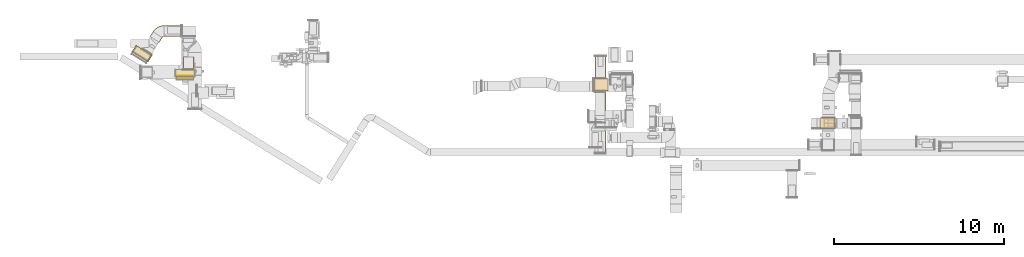
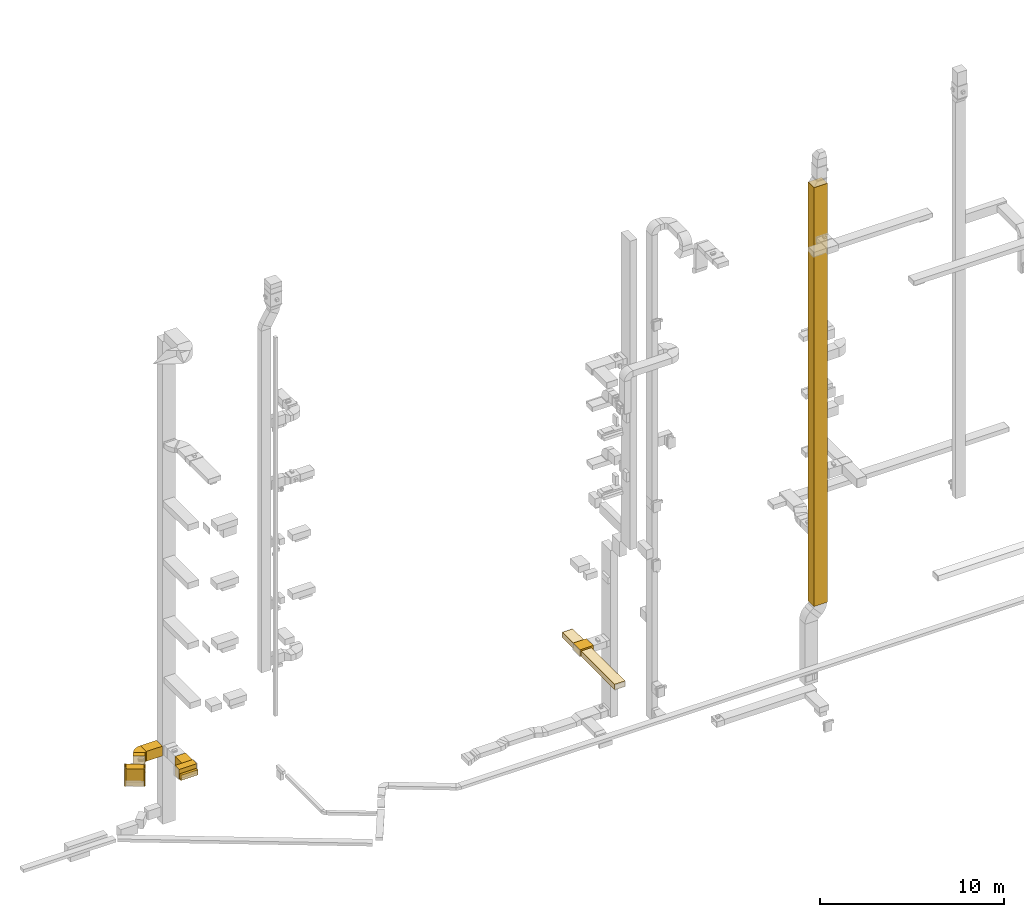
# One storey, part 1 of 29: 14 coverings.
"""IFC2X3 building model written with IfcOpenShell, lengths in millimetres."""

from ifc_helpers import new_model, entity, si_unit, converted_unit, derived_unit, direction, frame, frame_2d, origin, origin_2d_with_axis, place, context, subcontext, project, spatial, polyline, circle_curve, parameter, trimmed, segment, composite_curve, rectangle, outline, extrude, element, save


model = new_model("IFC2X3")

# Units and contexts
model_context = context("Model", 3, precision=0.01, world=origin(), true_north=direction((6.12303176911189e-17, 1.0)))
body_context = subcontext(model_context, "Body", "Model", "MODEL_VIEW")
ifc_project = project(units=[si_unit("LENGTHUNIT", "METRE", prefix="MILLI"), si_unit("AREAUNIT", "SQUARE_METRE"), si_unit("VOLUMEUNIT", "CUBIC_METRE"), converted_unit("PLANEANGLEUNIT", "DEGREE", entity("IfcRatioMeasure", 0.0174532925199433), si_unit("PLANEANGLEUNIT", "RADIAN"), dimensions=[0, 0, 0, 0, 0, 0, 0]), si_unit("MASSUNIT", "GRAM", prefix="KILO"), derived_unit("MASSDENSITYUNIT", [(si_unit("MASSUNIT", "GRAM", prefix="KILO"), 1), (si_unit("LENGTHUNIT", "METRE"), -3)]), derived_unit("MOMENTOFINERTIAUNIT", [(si_unit("LENGTHUNIT", "METRE"), 4)]), si_unit("TIMEUNIT", "SECOND"), si_unit("FREQUENCYUNIT", "HERTZ"), si_unit("THERMODYNAMICTEMPERATUREUNIT", "DEGREE_CELSIUS"), derived_unit("THERMALTRANSMITTANCEUNIT", [(si_unit("MASSUNIT", "GRAM", prefix="KILO"), 1), (si_unit("THERMODYNAMICTEMPERATUREUNIT", "KELVIN"), -1), (si_unit("TIMEUNIT", "SECOND"), -3)]), derived_unit("VOLUMETRICFLOWRATEUNIT", [(si_unit("LENGTHUNIT", "METRE"), 3), (si_unit("TIMEUNIT", "SECOND"), -1)]), derived_unit("MASSFLOWRATEUNIT", [(si_unit("MASSUNIT", "GRAM", prefix="KILO"), 1), (si_unit("TIMEUNIT", "SECOND"), -1)]), derived_unit("ROTATIONALFREQUENCYUNIT", [(si_unit("TIMEUNIT", "SECOND"), -1)]), si_unit("ELECTRICCURRENTUNIT", "AMPERE"), si_unit("ELECTRICVOLTAGEUNIT", "VOLT"), si_unit("POWERUNIT", "WATT"), si_unit("FORCEUNIT", "NEWTON", prefix="KILO"), si_unit("ILLUMINANCEUNIT", "LUX"), si_unit("LUMINOUSFLUXUNIT", "LUMEN"), si_unit("LUMINOUSINTENSITYUNIT", "CANDELA"), derived_unit("USERDEFINED", [(si_unit("MASSUNIT", "GRAM", prefix="KILO"), -1), (si_unit("LENGTHUNIT", "METRE"), -2), (si_unit("TIMEUNIT", "SECOND"), 3), (si_unit("LUMINOUSFLUXUNIT", "LUMEN"), 1)]), derived_unit("LINEARVELOCITYUNIT", [(si_unit("LENGTHUNIT", "METRE"), 1), (si_unit("TIMEUNIT", "SECOND"), -1)]), si_unit("PRESSUREUNIT", "PASCAL"), derived_unit("USERDEFINED", [(si_unit("LENGTHUNIT", "METRE"), -2), (si_unit("MASSUNIT", "GRAM", prefix="KILO"), 1), (si_unit("TIMEUNIT", "SECOND"), -2)]), derived_unit("LINEARFORCEUNIT", [(si_unit("MASSUNIT", "GRAM", prefix="KILO"), 1), (si_unit("LENGTHUNIT", "METRE"), 1), (si_unit("TIMEUNIT", "SECOND"), -2), (si_unit("LENGTHUNIT", "METRE"), -1)]), derived_unit("PLANARFORCEUNIT", [(si_unit("MASSUNIT", "GRAM", prefix="KILO"), 1), (si_unit("LENGTHUNIT", "METRE"), 1), (si_unit("TIMEUNIT", "SECOND"), -2), (si_unit("LENGTHUNIT", "METRE"), -2)])], contexts=[model_context])

# Site, building, storey
site_placement = place(None, frame((0.0, -0.00077364408347762, 0.0)))
site = spatial("IfcSite", under=ifc_project, at=site_placement, CompositionType="ELEMENT")
building_placement = place(site_placement, origin())
building = spatial("IfcBuilding", under=site, at=building_placement, CompositionType="ELEMENT")
storey_placement = place(building_placement, origin())
storey = spatial("IfcBuildingStorey", under=building, at=storey_placement, CompositionType="ELEMENT", Elevation=0.0)

# Coverings
covering_1_placement = place(storey_placement, frame((28415.0012184742, 12772.7217701701, 2475.0)))
element("IfcCovering", 1, at=covering_1_placement, inside=storey, PredefinedType="INSULATION", context=body_context, shape_type="SweptSolid", body=[
    extrude(rectangle(XDim=825.107316474216, YDim=749.999999999998, at=frame_2d((0.0, -1.08002495835535e-12), x_axis=(1.0, 0.0))), frame((412.553658237108, 375.0, 0.0), z_axis=(0.0, 0.0, 1.0), x_axis=(-1.0, 0.0, 0.0)), (0.0, 0.0, 1.0), 449.999999999999),
])
covering_2_placement = place(storey_placement, frame((28476.0506788633, 13517.7217701701, 2475.0)))
element("IfcCovering", 2, at=covering_2_placement, inside=storey, PredefinedType="INSULATION", context=body_context, shape_type="SweptSolid", body=[
    extrude(rectangle(XDim=1299.51814618853, YDim=650.0, at=frame_2d((-1.08002495835535e-12, 2.1600499167107e-12), x_axis=(1.0, 0.0))), frame((325.0, 649.759073094305, 0.0), z_axis=(0.0, 0.0, 1.0), x_axis=(0.0, 1.0, 0.0)), (0.0, 0.0, 1.0), 350.000000000001),
])
covering_3_placement = place(storey_placement, frame((28464.0983074609, 9142.07579712691, 2475.0)))
element("IfcCovering", 3, at=covering_3_placement, inside=storey, PredefinedType="INSULATION", context=body_context, shape_type="SweptSolid", body=[
    extrude(rectangle(XDim=3635.64597304317, YDim=650.0, at=frame_2d((-5.6843418860808e-13, 0.0), x_axis=(1.0, 0.0))), frame((325.0, 1817.82298652159, 0.0), z_axis=(0.0, 0.0, 1.0), x_axis=(0.0, -1.0, 0.0)), (0.0, 0.0, 1.0), 350.000000000001),
])
covering_4_placement = place(storey_placement, frame((4213.73846384671, 14052.5, 2475.0)))
element("IfcCovering", 4, at=covering_4_placement, inside=storey, PredefinedType="INSULATION", context=body_context, shape_type="SweptSolid", body=[
    extrude(rectangle(XDim=738.844290776113, YDim=650.0, at=origin_2d_with_axis()), frame((325.0, 369.422145388058, 0.0), z_axis=(0.0, 0.0, 1.0), x_axis=(0.0, -1.0, 0.0)), (0.0, 0.0, 1.0), 650.000000000001),
])
covering_5_placement = place(storey_placement, frame((3813.73846384665, 13450.1017206743, 2475.0)))
element("IfcCovering", 5, at=covering_5_placement, inside=storey, PredefinedType="INSULATION", context=body_context, shape_type="SweptSolid", body=[
    extrude(rectangle(XDim=162.39827932573, YDim=1050.0, at=frame_2d((0.0, 2.8421709430404e-13), x_axis=(1.0, 0.0))), frame((525.0, 81.1991396628746, 0.0), z_axis=(0.0, 0.0, 1.0), x_axis=(0.0, 1.0, 0.0)), (0.0, 0.0, 1.0), 349.999999999999),
])
covering_6_placement = place(storey_placement, frame((3785.84688819858, 13607.5, 2475.0)))
element("IfcCovering", 6, at=covering_6_placement, inside=storey, PredefinedType="INSULATION", context=body_context, shape_type="SweptSolid", body=[
    extrude(rectangle(XDim=1100.0, YDim=450.000000000002, at=origin_2d_with_axis()), frame((550.0, 225.0, 0.0)), (0.0, 0.0, 1.0), 650.000000000001),
])
covering_7_placement = place(storey_placement, frame((3813.73846384665, 13612.5, 2475.0)))
element("IfcCovering", 7, at=covering_7_placement, inside=storey, PredefinedType="INSULATION", context=body_context, shape_type="SweptSolid", body=[
    extrude(rectangle(XDim=1050.0, YDim=51.0959999999994, at=frame_2d((-2.8421709430404e-13, 2.16537898722891e-12), x_axis=(1.0, 0.0))), frame((525.0, 25.5479999999986, 0.0)), (0.0, 0.0, 1.0), 349.999999999999),
])
covering_8_placement = place(storey_placement, frame((1272.46372759647, 14529.8528003857, 2025.0)))
element("IfcCovering", 8, at=covering_8_placement, inside=storey, PredefinedType="INSULATION", context=body_context, shape_type="SweptSolid", body=[
    extrude(rectangle(XDim=1000.0, YDim=449.999999999999, at=frame_2d((-5.96855898038484e-13, 9.37916411203332e-13), x_axis=(1.0, 0.0))), frame((543.255882522377, 455.770453785952, 0.0), z_axis=(0.0, 0.0, 1.0), x_axis=(0.848048096097044, -0.529919264328235, 0.0)), (0.0, 0.0, 1.0), 1150.0),
])
covering_9_placement = place(storey_placement, frame((1230.06132279162, 15059.772064714, 2025.0)))
element("IfcCovering", 9, at=covering_9_placement, inside=storey, PredefinedType="INSULATION", context=body_context, shape_type="SweptSolid", body=[
    extrude(rectangle(XDim=50.0000000000009, YDim=450.0, at=frame_2d((-4.65405491922866e-13, 9.80548975348938e-13), x_axis=(1.0, 0.0))), frame((140.43303687628, 204.058803230039, 0.0), z_axis=(0.0, 0.0, 1.0), x_axis=(0.848048096097048, -0.52991926432823, 0.0)), (0.0, 0.0, 1.0), 1150.0),
])
covering_10_placement = place(storey_placement, frame((3108.61579884427, 15984.9756321925, 2460.0)))
element("IfcCovering", 10, at=covering_10_placement, inside=storey, PredefinedType="INSULATION", context=body_context, shape_type="SweptSolid", body=[
    extrude(rectangle(XDim=1014.71471811025, YDim=650.0, at=origin_2d_with_axis()), frame((507.357359055125, 325.0, 0.0), z_axis=(0.0, 0.0, 1.0), x_axis=(-1.0, 0.0, 0.0)), (0.0, 0.0, 1.0), 650.000000000001),
])
covering_11_placement = place(storey_placement, frame((2276.07139059339, 15645.665480935, 2460.0)))
element("IfcCovering", 11, at=covering_11_placement, inside=storey, PredefinedType="INSULATION", context=body_context, shape_type="SweptSolid", body=[
    extrude(rectangle(XDim=330.818571009889, YDim=649.999999999998, at=frame_2d((7.8159700933611e-13, 8.24229573481716e-13), x_axis=(1.0, 0.0))), frame((363.269198119378, 312.498790555917, 0.0), z_axis=(0.0, 0.0, 1.0), x_axis=(-0.529919264328237, -0.848048096097043, 0.0)), (0.0, 0.0, 1.0), 649.999999999999),
])
covering_12_placement = place(storey_placement, frame((2120.51182369352, 14503.3568371693, 2025.0)))
element("IfcCovering", 12, at=covering_12_placement, inside=storey, PredefinedType="INSULATION", context=body_context, shape_type="SweptSolid", body=[
    extrude(rectangle(XDim=50.0000000000007, YDim=450.0, at=frame_2d((4.65405491922866e-13, -9.9475983006414e-13), x_axis=(1.0, 0.0))), frame((140.43303687628, 204.058803230037, 0.0), z_axis=(0.0, 0.0, 1.0), x_axis=(-0.848048096097046, 0.529919264328233, 0.0)), (0.0, 0.0, 1.0), 1150.0),
])
covering_13_placement = place(storey_placement, frame((2449.78325213316, 15924.6202679976, 2460.0)))
element("IfcCovering", 13, at=covering_13_placement, inside=storey, PredefinedType="INSULATION", context=body_context, shape_type="SweptSolid", body=[
    extrude(outline(composite_curve([segment(polyline([(-277.991926432823, 84.8048096097035), (66.4555953805334, -466.426452853373)]), True, "CONTINUOUS"), segment(trimmed(circle_curve(frame_2d((-344.231834473854, 190.810821621833), x_axis=(1.0, 0.0)), 775.0), [parameter(302.000000006421)], [parameter(0.0)], True, "PARAMETER"), True, "CONTINUOUS"), segment(polyline([(430.768165526145, 190.810821621833), (-219.231834473854, 190.810821621833)]), True, "CONTINUOUS"), segment(trimmed(circle_curve(frame_2d((-344.231834473854, 190.810821621833), x_axis=(1.0, 0.0)), 125.0), [parameter(302.00000000642)], [parameter(360.0)], True, "PARAMETER"), False, "CONTINUOUS")], self_intersect=False)), frame((468.021725089288, 279.587198668741, 0.0), z_axis=(0.0, 0.0, -1.0), x_axis=(0.0, 1.0, 0.0)), (0.0, 0.0, -1.0), 650.0),
])
covering_14_placement = place(storey_placement, frame((41759.8655138023, 10559.9897523177, 2454.49686225744)))
element("IfcCovering", 14, at=covering_14_placement, inside=storey, PredefinedType="INSULATION", context=body_context, shape_type="SweptSolid", body=[
    extrude(rectangle(XDim=849.999999999997, YDim=650.0, at=origin_2d_with_axis()), frame((425.0, 325.0, 0.0), z_axis=(0.0, 0.0, 1.0), x_axis=(-1.0, 0.0, 0.0)), (0.0, 0.0, 1.0), 27715.1242230804),
])

save(model, "model.ifc")
